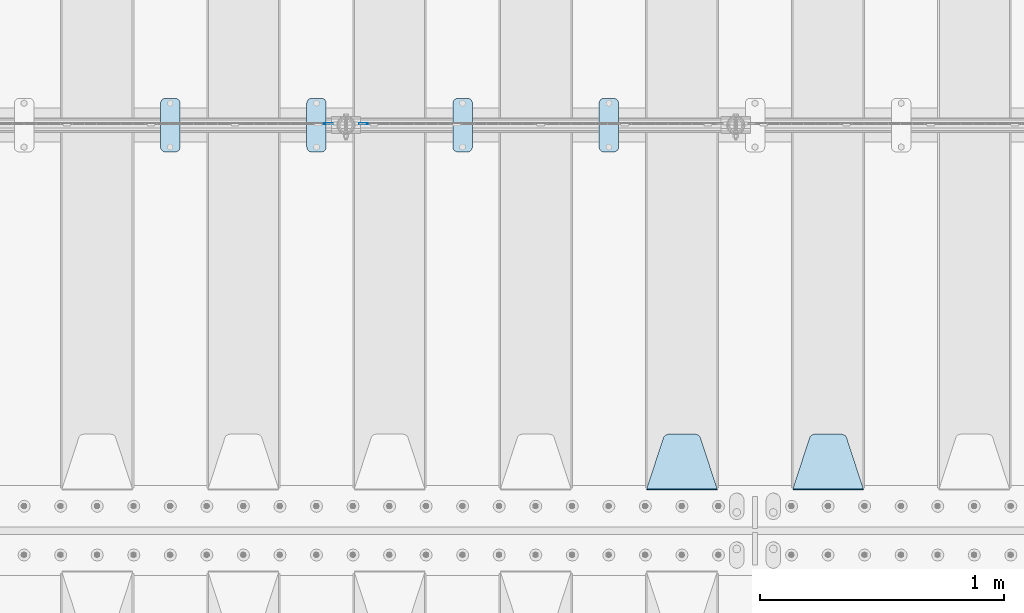
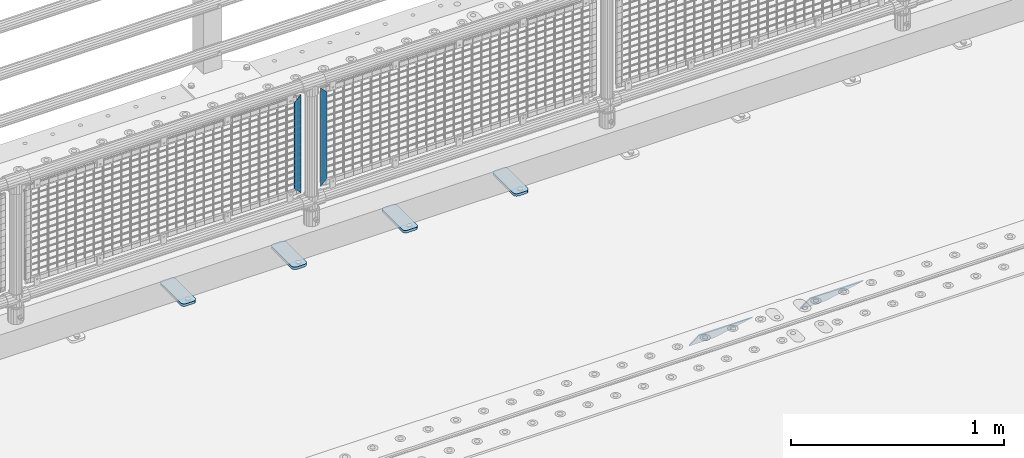
# One storey, part 173 of 208: 8 plates.
"""IFC2X3 building model written with IfcOpenShell, lengths in millimetres."""

import ifcopenshell
import ifcopenshell.guid

model = None  # the IFC model being written
_history = None  # IfcOwnerHistory: only IFC2X3 demands one
_inside = {}  # id of a spatial element -> (the spatial element, [elements in it])
_under = {}  # id of a project, library or spatial element -> (it, [spatial elements below it])
_declared = {}  # id of a project -> (the project, [libraries it declares])
_typed = {}  # id of a type object -> (the type object, [elements of that type])
_made_of = {}  # id of a material, layer set ... -> (it, [elements and type objects made of it])


def new_model(schema):
    """Start an empty IFC model of exactly this schema.

    Asked for "IFC4X3", IfcOpenShell would pick the latest addendum, in which some entities
    have other attributes; the version numbers below select the first issue.
    IFC2X3 requires an IfcOwnerHistory on every rooted entity: one is made here for all.
    """
    global model, _history
    if schema == "IFC4X3":
        model = ifcopenshell.file(schema_version=(4, 3, 0, 0))
    else:
        model = ifcopenshell.file(schema=schema)
    _inside.clear()
    _under.clear()
    _declared.clear()
    _typed.clear()
    _made_of.clear()
    _history = None
    if model.schema == "IFC2X3":
        org = make("IfcOrganization", Name="unknown")
        user = make(
            "IfcPersonAndOrganization",
            ThePerson=make("IfcPerson", FamilyName="unknown"),
            TheOrganization=org,
        )
        app = make(
            "IfcApplication",
            ApplicationDeveloper=org,
            Version="unknown",
            ApplicationFullName="unknown",
            ApplicationIdentifier="unknown",
        )
        _history = make(
            "IfcOwnerHistory",
            OwningUser=user,
            OwningApplication=app,
            ChangeAction="ADDED",
            CreationDate=0,
        )
    return model


def make(cls, **values):
    """One entity of the class cls with the attributes given. An attribute that is None is left unset."""
    return model.create_entity(
        cls, **{name: value for name, value in values.items() if value is not None}
    )


def rooted(cls, **values):
    """An entity with a GlobalId (a new one), such as an element, a storey or a relation."""
    return make(cls, GlobalId=ifcopenshell.guid.new(), OwnerHistory=_history, **values)


def si_unit(unit_type, name, prefix=None):
    """IfcSIUnit, for example si_unit("LENGTHUNIT", "METRE", prefix="MILLI")."""
    return make("IfcSIUnit", UnitType=unit_type, Prefix=prefix, Name=name)


def assignment(units):
    """IfcUnitAssignment: the units of a project."""
    return None if units is None else make("IfcUnitAssignment", Units=units)


def point(xyz):
    """IfcCartesianPoint."""
    return None if xyz is None else make("IfcCartesianPoint", Coordinates=xyz)


def direction(xyz):
    """IfcDirection."""
    return None if xyz is None else make("IfcDirection", DirectionRatios=xyz)


def frame(location, z_axis=None, x_axis=None):
    """IfcAxis2Placement3D, a coordinate frame: its origin and axes. An axis left out is left unset."""
    return make(
        "IfcAxis2Placement3D",
        Location=point(location),
        Axis=direction(z_axis),
        RefDirection=direction(x_axis),
    )


def origin_with_axes():
    """The frame at (0, 0, 0) with the z axis (0, 0, 1) and the x axis (1, 0, 0) written out."""
    return frame((0.0, 0.0, 0.0), z_axis=(0.0, 0.0, 1.0), x_axis=(1.0, 0.0, 0.0))


def place(relative_to, where):
    """IfcLocalPlacement: puts the frame where relative to a parent placement (None: the world)."""
    return make(
        "IfcLocalPlacement", PlacementRelTo=relative_to, RelativePlacement=where
    )


def context(
    kind, dimensions, precision=None, world=None, true_north=None, identifier=None
):
    """IfcGeometricRepresentationContext, for example the 3D "Model" context."""
    return make(
        "IfcGeometricRepresentationContext",
        ContextIdentifier=identifier,
        ContextType=kind,
        CoordinateSpaceDimension=dimensions,
        Precision=precision,
        WorldCoordinateSystem=world,
        TrueNorth=true_north,
    )


def subcontext(parent, identifier, kind, view, scale=None):
    """IfcGeometricRepresentationSubContext, for example "Body" below "Model"."""
    return make(
        "IfcGeometricRepresentationSubContext",
        ContextIdentifier=identifier,
        ContextType=kind,
        ParentContext=parent,
        TargetScale=scale,
        TargetView=view,
    )


def project(units=None, contexts=None):
    """IfcProject with its units and contexts."""
    return rooted(
        "IfcProject",
        Name="project",
        RepresentationContexts=contexts,
        UnitsInContext=assignment(units),
    )


def spatial(cls, under=None, at=None, **own):
    """A site, building, storey or space (cls), placed at a placement, below another one or the project."""
    s = rooted(cls, ObjectPlacement=at, **own)
    if under is not None:
        _under.setdefault(under.id(), (under, []))[1].append(s)
    return s


def faces_of(points, faces, orient=None, outer=None):
    """IfcFace entities. A face is a list of loops; a loop is a list of indices into points, from 0.

    orient and outer hold one flag for each loop. By default every Orientation is true, the
    first loop of a face is its IfcFaceOuterBound and the others are IfcFaceBound.
    """
    made = []
    for i, loops in enumerate(faces):
        bounds = []
        for j, loop in enumerate(loops):
            is_outer = j == 0 if outer is None else outer[i][j]
            bounds.append(
                make(
                    "IfcFaceOuterBound" if is_outer else "IfcFaceBound",
                    Bound=make("IfcPolyLoop", Polygon=[points[k] for k in loop]),
                    Orientation=True if orient is None else orient[i][j],
                )
            )
        made.append(make("IfcFace", Bounds=bounds))
    return made


def faceted_brep(points, faces, orient=None, outer=None, voids=None):
    """IfcFacetedBrep: a solid bounded by flat faces; with voids (closed shells), ...WithVoids."""
    shared = [point(p) for p in points]
    hull = make("IfcClosedShell", CfsFaces=faces_of(shared, faces, orient, outer))
    if voids is None:
        return make("IfcFacetedBrep", Outer=hull)
    return make(
        "IfcFacetedBrepWithVoids",
        Outer=hull,
        Voids=[
            make(cls, CfsFaces=faces_of(shared, fs, o, b)) for cls, fs, o, b in voids
        ],
    )


def shape(context_of_items, identifier, shape_type, items):
    """IfcShapeRepresentation: the items that make up one representation, for example the "Body"."""
    return make(
        "IfcShapeRepresentation",
        ContextOfItems=context_of_items,
        RepresentationIdentifier=identifier,
        RepresentationType=shape_type,
        Items=items,
    )


def material(Name=None, Category=None):
    """IfcMaterial."""
    return make("IfcMaterial", Name=Name, Category=Category)


def made_of(thing, what):
    """Note that an element or type object is made of a material, layer set ...; save() writes the relation."""
    if what is not None:
        _made_of.setdefault(what.id(), (what, []))[1].append(thing)
    return thing


def type_object(cls, material=None, **own):
    """A type object (cls), such as IfcWallType, which elements share."""
    return made_of(rooted(cls, **own), material)


def element(
    cls,
    number,
    at=None,
    inside=None,
    cuts=None,
    type_object=None,
    material=None,
    context=None,
    identifier="Body",
    shape_type=None,
    held_by="IfcProductDefinitionShape",
    body=None,
    shapes=None,
    **own,
):
    """One element of the class cls, such as IfcWall. Its Tag is "e" and its number.

    at: its placement. inside: the storey or other place that contains it. cuts: it is an
    opening in that element (IfcRelVoidsElement). A single representation is given by context,
    identifier, shape_type and body (its items); several are given by shapes. held_by: the class
    of the entity that holds the representations. save() writes the other relations.
    """
    e = rooted(cls, Tag="e%d" % number, ObjectPlacement=at, **own)
    if body is not None:
        shapes = [shape(context, identifier, shape_type, body)]
    if shapes is not None:
        e.Representation = make(held_by, Representations=shapes)
    if inside is not None:
        _inside.setdefault(inside.id(), (inside, []))[1].append(e)
    if cuts is not None:
        rooted(
            "IfcRelVoidsElement", RelatingBuildingElement=cuts, RelatedOpeningElement=e
        )
    if type_object is not None:
        _typed.setdefault(type_object.id(), (type_object, []))[1].append(e)
    return made_of(e, material)


def aggregate(whole, parts):
    """IfcRelAggregates: a whole, such as a stair, and the parts it consists of."""
    return rooted("IfcRelAggregates", RelatingObject=whole, RelatedObjects=parts)


def save(model, path):
    """Write the relations noted so far, then the file.

    IfcRelAggregates (storeys below a building ...), IfcRelContainedInSpatialStructure (elements
    in a storey), IfcRelDefinesByType, IfcRelAssociatesMaterial and IfcRelDeclares: one each for
    every whole, place, type object, material and project.
    """
    for whole, parts in _under.values():
        aggregate(whole, parts)
    for where, things in _inside.values():
        rooted(
            "IfcRelContainedInSpatialStructure",
            RelatedElements=things,
            RelatingStructure=where,
        )
    for kind, things in _typed.values():
        rooted("IfcRelDefinesByType", RelatedObjects=things, RelatingType=kind)
    for what, things in _made_of.values():
        rooted("IfcRelAssociatesMaterial", RelatedObjects=things, RelatingMaterial=what)
    for by, libraries in _declared.values():
        rooted("IfcRelDeclares", RelatingContext=by, RelatedDefinitions=libraries)
    model.write(path)


model = new_model("IFC2X3")

# Units and contexts
model_context = context("Model", 3, precision=1e-05, world=origin_with_axes())
body_context = subcontext(model_context, "Body", "Model", "MODEL_VIEW")
ifc_project = project(units=[si_unit("LENGTHUNIT", "METRE", prefix="MILLI"), si_unit("AREAUNIT", "SQUARE_METRE"), si_unit("VOLUMEUNIT", "CUBIC_METRE"), si_unit("MASSUNIT", "GRAM", prefix="KILO"), si_unit("TIMEUNIT", "SECOND"), si_unit("PLANEANGLEUNIT", "RADIAN"), si_unit("SOLIDANGLEUNIT", "STERADIAN"), si_unit("THERMODYNAMICTEMPERATUREUNIT", "DEGREE_CELSIUS"), si_unit("LUMINOUSINTENSITYUNIT", "LUMEN")], contexts=[model_context])

# Site, building, storey
site_placement = place(None, origin_with_axes())
site = spatial("IfcSite", under=ifc_project, at=site_placement, CompositionType="ELEMENT")
building_placement = place(site_placement, origin_with_axes())
building = spatial("IfcBuilding", under=site, at=building_placement, Name="Standard", CompositionType="ELEMENT")
storey_placement = place(building_placement, origin_with_axes())
storey = spatial("IfcBuildingStorey", under=building, at=storey_placement, Name="Undefined", CompositionType="ELEMENT", Elevation=0.0)

# Plates
ifc_material_1 = material(Name="STEEL/S355J2")
plate_type_1 = type_object("IfcPlateType", PredefinedType="NOTDEFINED")
plate_1_placement = place(storey_placement, frame((-37590.0, 4774.5, 21.0199999999977), z_axis=(1.0, 0.0, 0.0), x_axis=(0.0, -1.0, 0.0)))
element("IfcPlate", 1, at=plate_1_placement, inside=storey, type_object=plate_type_1, material=ifc_material_1, context=body_context, shape_type="Brep", body=[
    faceted_brep([(0.0, -7.0, 20.0), (0.0, -7.0, 60.0), (0.0, 7.0, 60.0), (0.0, 7.0, 20.0), (0.384294391935327, -7.0, 63.9018064403208), (0.384294391935327, 7.0, 63.9018064403208), (1.52240934977453, -7.0, 67.6536686473009), (1.52240934977453, 7.0, 67.6536686473009), (3.37060775394912, -7.0, 71.1114046603907), (3.37060775394912, 7.0, 71.1114046603907), (5.85786437626939, -7.0, 74.1421356237297), (5.85786437626939, 7.0, 74.1421356237297), (8.8885953396084, -7.0, 76.62939224605), (8.8885953396084, 7.0, 76.62939224605), (12.3463313526981, -7.0, 78.4775906502255), (12.3463313526981, 7.0, 78.4775906502255), (16.0981935596774, -7.0, 79.6157056080629), (16.0981935596774, 7.0, 79.6157056080629), (20.0, -7.0, 80.0), (20.0, 7.0, 80.0), (200.0, -7.0, 80.0), (200.0, 7.0, 80.0), (203.901806440323, -7.0, 79.6157056080629), (203.901806440323, 7.0, 79.6157056080629), (207.653668647302, -7.0, 78.4775906502255), (207.653668647302, 7.0, 78.4775906502255), (211.111404660393, -7.0, 76.62939224605), (211.111404660393, 7.0, 76.62939224605), (214.142135623731, -7.0, 74.1421356237297), (214.142135623731, 7.0, 74.1421356237297), (216.629392246051, -7.0, 71.1114046603907), (216.629392246051, 7.0, 71.1114046603907), (218.477590650225, -7.0, 67.6536686473009), (218.477590650225, 7.0, 67.6536686473009), (219.615705608065, -7.0, 63.9018064403208), (219.615705608065, 7.0, 63.9018064403208), (220.0, -7.0, 60.0), (220.0, 7.0, 60.0), (220.0, -7.0, 20.0), (220.0, 7.0, 20.0), (219.615705608065, -7.0, 16.0981935596792), (219.615705608065, 7.0, 16.0981935596792), (218.477590650225, -7.0, 12.3463313526991), (218.477590650225, 7.0, 12.3463313526991), (216.629392246051, -7.0, 8.88859533960931), (216.629392246051, 7.0, 8.88859533960931), (214.142135623731, -7.0, 5.8578643762703), (214.142135623731, 7.0, 5.8578643762703), (211.111404660393, -7.0, 3.37060775395003), (211.111404660393, 7.0, 3.37060775395003), (207.653668647302, -7.0, 1.52240934977453), (207.653668647302, 7.0, 1.52240934977453), (203.901806440323, -7.0, 0.384294391937146), (203.901806440323, 7.0, 0.384294391937146), (200.0, -7.0, 0.0), (200.0, 7.0, 0.0), (20.0, -7.0, 0.0), (20.0, 7.0, 0.0), (16.0981935596774, -7.0, 0.384294391937146), (16.0981935596774, 7.0, 0.384294391937146), (12.3463313526981, -7.0, 1.52240934977453), (12.3463313526981, 7.0, 1.52240934977453), (8.8885953396084, -7.0, 3.37060775395003), (8.8885953396084, 7.0, 3.37060775395003), (5.85786437626939, -7.0, 5.8578643762703), (5.85786437626939, 7.0, 5.8578643762703), (3.37060775394912, -7.0, 8.88859533960931), (3.37060775394912, 7.0, 8.88859533960931), (1.52240934977453, -7.0, 12.3463313526991), (1.52240934977453, 7.0, 12.3463313526991), (0.384294391935327, -7.0, 16.0981935596792), (0.384294391935327, 7.0, 16.0981935596792)], [[[0, 1, 2, 3]], [[1, 4, 5, 2]], [[4, 6, 7, 5]], [[6, 8, 9, 7]], [[8, 10, 11, 9]], [[10, 12, 13, 11]], [[12, 14, 15, 13]], [[14, 16, 17, 15]], [[16, 18, 19, 17]], [[18, 20, 21, 19]], [[20, 22, 23, 21]], [[22, 24, 25, 23]], [[24, 26, 27, 25]], [[26, 28, 29, 27]], [[28, 30, 31, 29]], [[30, 32, 33, 31]], [[32, 34, 35, 33]], [[34, 36, 37, 35]], [[36, 38, 39, 37]], [[38, 40, 41, 39]], [[40, 42, 43, 41]], [[42, 44, 45, 43]], [[44, 46, 47, 45]], [[46, 48, 49, 47]], [[48, 50, 51, 49]], [[50, 52, 53, 51]], [[52, 54, 55, 53]], [[54, 56, 57, 55]], [[56, 58, 59, 57]], [[58, 60, 61, 59]], [[60, 62, 63, 61]], [[62, 64, 65, 63]], [[64, 66, 67, 65]], [[66, 68, 69, 67]], [[68, 70, 71, 69]], [[70, 0, 3, 71]], [[5, 7, 9, 11, 13, 15, 17, 19, 21, 23, 25, 27, 29, 31, 33, 35, 37, 39, 41, 43, 45, 47, 49, 51, 53, 55, 57, 59, 61, 63, 65, 67, 69, 71, 3, 2]], [[70, 68, 66, 64, 62, 60, 58, 56, 54, 52, 50, 48, 46, 44, 42, 40, 38, 36, 34, 32, 30, 28, 26, 24, 22, 20, 18, 16, 14, 12, 10, 8, 6, 4, 1, 0]]]),
])
plate_2_placement = place(storey_placement, frame((-38190.0, 4774.5, 21.0199999999977), z_axis=(1.0, 0.0, 0.0), x_axis=(0.0, -1.0, 0.0)))
element("IfcPlate", 2, at=plate_2_placement, inside=storey, type_object=plate_type_1, material=ifc_material_1, context=body_context, shape_type="Brep", body=[
    faceted_brep([(0.0, -7.0, 20.0), (0.0, -7.0, 60.0), (0.0, 7.0, 60.0), (0.0, 7.0, 20.0), (0.384294391935327, -7.0, 63.9018064403208), (0.384294391935327, 7.0, 63.9018064403208), (1.52240934977453, -7.0, 67.6536686473009), (1.52240934977453, 7.0, 67.6536686473009), (3.37060775394912, -7.0, 71.1114046603907), (3.37060775394912, 7.0, 71.1114046603907), (5.85786437626939, -7.0, 74.1421356237297), (5.85786437626939, 7.0, 74.1421356237297), (8.8885953396084, -7.0, 76.62939224605), (8.8885953396084, 7.0, 76.62939224605), (12.3463313526981, -7.0, 78.4775906502255), (12.3463313526981, 7.0, 78.4775906502255), (16.0981935596774, -7.0, 79.6157056080629), (16.0981935596774, 7.0, 79.6157056080629), (20.0, -7.0, 80.0), (20.0, 7.0, 80.0), (200.0, -7.0, 80.0), (200.0, 7.0, 80.0), (203.901806440323, -7.0, 79.6157056080629), (203.901806440323, 7.0, 79.6157056080629), (207.653668647302, -7.0, 78.4775906502255), (207.653668647302, 7.0, 78.4775906502255), (211.111404660393, -7.0, 76.62939224605), (211.111404660393, 7.0, 76.62939224605), (214.142135623731, -7.0, 74.1421356237297), (214.142135623731, 7.0, 74.1421356237297), (216.629392246051, -7.0, 71.1114046603907), (216.629392246051, 7.0, 71.1114046603907), (218.477590650225, -7.0, 67.6536686473009), (218.477590650225, 7.0, 67.6536686473009), (219.615705608065, -7.0, 63.9018064403208), (219.615705608065, 7.0, 63.9018064403208), (220.0, -7.0, 60.0), (220.0, 7.0, 60.0), (220.0, -7.0, 20.0), (220.0, 7.0, 20.0), (219.615705608065, -7.0, 16.0981935596792), (219.615705608065, 7.0, 16.0981935596792), (218.477590650225, -7.0, 12.3463313526991), (218.477590650225, 7.0, 12.3463313526991), (216.629392246051, -7.0, 8.88859533960931), (216.629392246051, 7.0, 8.88859533960931), (214.142135623731, -7.0, 5.8578643762703), (214.142135623731, 7.0, 5.8578643762703), (211.111404660393, -7.0, 3.37060775395003), (211.111404660393, 7.0, 3.37060775395003), (207.653668647302, -7.0, 1.52240934977453), (207.653668647302, 7.0, 1.52240934977453), (203.901806440323, -7.0, 0.384294391937146), (203.901806440323, 7.0, 0.384294391937146), (200.0, -7.0, 0.0), (200.0, 7.0, 0.0), (20.0, -7.0, 0.0), (20.0, 7.0, 0.0), (16.0981935596774, -7.0, 0.384294391937146), (16.0981935596774, 7.0, 0.384294391937146), (12.3463313526981, -7.0, 1.52240934977453), (12.3463313526981, 7.0, 1.52240934977453), (8.8885953396084, -7.0, 3.37060775395003), (8.8885953396084, 7.0, 3.37060775395003), (5.85786437626939, -7.0, 5.8578643762703), (5.85786437626939, 7.0, 5.8578643762703), (3.37060775394912, -7.0, 8.88859533960931), (3.37060775394912, 7.0, 8.88859533960931), (1.52240934977453, -7.0, 12.3463313526991), (1.52240934977453, 7.0, 12.3463313526991), (0.384294391935327, -7.0, 16.0981935596792), (0.384294391935327, 7.0, 16.0981935596792)], [[[0, 1, 2, 3]], [[1, 4, 5, 2]], [[4, 6, 7, 5]], [[6, 8, 9, 7]], [[8, 10, 11, 9]], [[10, 12, 13, 11]], [[12, 14, 15, 13]], [[14, 16, 17, 15]], [[16, 18, 19, 17]], [[18, 20, 21, 19]], [[20, 22, 23, 21]], [[22, 24, 25, 23]], [[24, 26, 27, 25]], [[26, 28, 29, 27]], [[28, 30, 31, 29]], [[30, 32, 33, 31]], [[32, 34, 35, 33]], [[34, 36, 37, 35]], [[36, 38, 39, 37]], [[38, 40, 41, 39]], [[40, 42, 43, 41]], [[42, 44, 45, 43]], [[44, 46, 47, 45]], [[46, 48, 49, 47]], [[48, 50, 51, 49]], [[50, 52, 53, 51]], [[52, 54, 55, 53]], [[54, 56, 57, 55]], [[56, 58, 59, 57]], [[58, 60, 61, 59]], [[60, 62, 63, 61]], [[62, 64, 65, 63]], [[64, 66, 67, 65]], [[66, 68, 69, 67]], [[68, 70, 71, 69]], [[70, 0, 3, 71]], [[5, 7, 9, 11, 13, 15, 17, 19, 21, 23, 25, 27, 29, 31, 33, 35, 37, 39, 41, 43, 45, 47, 49, 51, 53, 55, 57, 59, 61, 63, 65, 67, 69, 71, 3, 2]], [[70, 68, 66, 64, 62, 60, 58, 56, 54, 52, 50, 48, 46, 44, 42, 40, 38, 36, 34, 32, 30, 28, 26, 24, 22, 20, 18, 16, 14, 12, 10, 8, 6, 4, 1, 0]]]),
])
plate_3_placement = place(storey_placement, frame((-38790.0, 4774.5, 21.0199999999977), z_axis=(1.0, 0.0, 0.0), x_axis=(0.0, -1.0, 0.0)))
element("IfcPlate", 3, at=plate_3_placement, inside=storey, type_object=plate_type_1, material=ifc_material_1, context=body_context, shape_type="Brep", body=[
    faceted_brep([(0.0, -7.0, 20.0), (0.0, -7.0, 60.0), (0.0, 7.0, 60.0), (0.0, 7.0, 20.0), (0.384294391935327, -7.0, 63.9018064403208), (0.384294391935327, 7.0, 63.9018064403208), (1.52240934977453, -7.0, 67.6536686473009), (1.52240934977453, 7.0, 67.6536686473009), (3.37060775394912, -7.0, 71.1114046603907), (3.37060775394912, 7.0, 71.1114046603907), (5.85786437626939, -7.0, 74.1421356237297), (5.85786437626939, 7.0, 74.1421356237297), (8.8885953396084, -7.0, 76.62939224605), (8.8885953396084, 7.0, 76.62939224605), (12.3463313526981, -7.0, 78.4775906502255), (12.3463313526981, 7.0, 78.4775906502255), (16.0981935596774, -7.0, 79.6157056080629), (16.0981935596774, 7.0, 79.6157056080629), (20.0, -7.0, 80.0), (20.0, 7.0, 80.0), (200.0, -7.0, 80.0), (200.0, 7.0, 80.0), (203.901806440323, -7.0, 79.6157056080629), (203.901806440323, 7.0, 79.6157056080629), (207.653668647302, -7.0, 78.4775906502255), (207.653668647302, 7.0, 78.4775906502255), (211.111404660393, -7.0, 76.62939224605), (211.111404660393, 7.0, 76.62939224605), (214.142135623731, -7.0, 74.1421356237297), (214.142135623731, 7.0, 74.1421356237297), (216.629392246051, -7.0, 71.1114046603907), (216.629392246051, 7.0, 71.1114046603907), (218.477590650225, -7.0, 67.6536686473009), (218.477590650225, 7.0, 67.6536686473009), (219.615705608065, -7.0, 63.9018064403208), (219.615705608065, 7.0, 63.9018064403208), (220.0, -7.0, 60.0), (220.0, 7.0, 60.0), (220.0, -7.0, 20.0), (220.0, 7.0, 20.0), (219.615705608065, -7.0, 16.0981935596792), (219.615705608065, 7.0, 16.0981935596792), (218.477590650225, -7.0, 12.3463313526991), (218.477590650225, 7.0, 12.3463313526991), (216.629392246051, -7.0, 8.88859533960931), (216.629392246051, 7.0, 8.88859533960931), (214.142135623731, -7.0, 5.8578643762703), (214.142135623731, 7.0, 5.8578643762703), (211.111404660393, -7.0, 3.37060775395003), (211.111404660393, 7.0, 3.37060775395003), (207.653668647302, -7.0, 1.52240934977453), (207.653668647302, 7.0, 1.52240934977453), (203.901806440323, -7.0, 0.384294391937146), (203.901806440323, 7.0, 0.384294391937146), (200.0, -7.0, 0.0), (200.0, 7.0, 0.0), (20.0, -7.0, 0.0), (20.0, 7.0, 0.0), (16.0981935596774, -7.0, 0.384294391937146), (16.0981935596774, 7.0, 0.384294391937146), (12.3463313526981, -7.0, 1.52240934977453), (12.3463313526981, 7.0, 1.52240934977453), (8.8885953396084, -7.0, 3.37060775395003), (8.8885953396084, 7.0, 3.37060775395003), (5.85786437626939, -7.0, 5.8578643762703), (5.85786437626939, 7.0, 5.8578643762703), (3.37060775394912, -7.0, 8.88859533960931), (3.37060775394912, 7.0, 8.88859533960931), (1.52240934977453, -7.0, 12.3463313526991), (1.52240934977453, 7.0, 12.3463313526991), (0.384294391935327, -7.0, 16.0981935596792), (0.384294391935327, 7.0, 16.0981935596792)], [[[0, 1, 2, 3]], [[1, 4, 5, 2]], [[4, 6, 7, 5]], [[6, 8, 9, 7]], [[8, 10, 11, 9]], [[10, 12, 13, 11]], [[12, 14, 15, 13]], [[14, 16, 17, 15]], [[16, 18, 19, 17]], [[18, 20, 21, 19]], [[20, 22, 23, 21]], [[22, 24, 25, 23]], [[24, 26, 27, 25]], [[26, 28, 29, 27]], [[28, 30, 31, 29]], [[30, 32, 33, 31]], [[32, 34, 35, 33]], [[34, 36, 37, 35]], [[36, 38, 39, 37]], [[38, 40, 41, 39]], [[40, 42, 43, 41]], [[42, 44, 45, 43]], [[44, 46, 47, 45]], [[46, 48, 49, 47]], [[48, 50, 51, 49]], [[50, 52, 53, 51]], [[52, 54, 55, 53]], [[54, 56, 57, 55]], [[56, 58, 59, 57]], [[58, 60, 61, 59]], [[60, 62, 63, 61]], [[62, 64, 65, 63]], [[64, 66, 67, 65]], [[66, 68, 69, 67]], [[68, 70, 71, 69]], [[70, 0, 3, 71]], [[5, 7, 9, 11, 13, 15, 17, 19, 21, 23, 25, 27, 29, 31, 33, 35, 37, 39, 41, 43, 45, 47, 49, 51, 53, 55, 57, 59, 61, 63, 65, 67, 69, 71, 3, 2]], [[70, 68, 66, 64, 62, 60, 58, 56, 54, 52, 50, 48, 46, 44, 42, 40, 38, 36, 34, 32, 30, 28, 26, 24, 22, 20, 18, 16, 14, 12, 10, 8, 6, 4, 1, 0]]]),
])
plate_4_placement = place(storey_placement, frame((-39390.0, 4774.5, 21.0199999999977), z_axis=(1.0, 0.0, 0.0), x_axis=(0.0, -1.0, 0.0)))
element("IfcPlate", 4, at=plate_4_placement, inside=storey, type_object=plate_type_1, material=ifc_material_1, context=body_context, shape_type="Brep", body=[
    faceted_brep([(0.0, -7.0, 20.0), (0.0, -7.0, 60.0), (0.0, 7.0, 60.0), (0.0, 7.0, 20.0), (0.384294391935327, -7.0, 63.9018064403208), (0.384294391935327, 7.0, 63.9018064403208), (1.52240934977453, -7.0, 67.6536686473009), (1.52240934977453, 7.0, 67.6536686473009), (3.37060775394912, -7.0, 71.1114046603907), (3.37060775394912, 7.0, 71.1114046603907), (5.85786437626939, -7.0, 74.1421356237297), (5.85786437626939, 7.0, 74.1421356237297), (8.8885953396084, -7.0, 76.62939224605), (8.8885953396084, 7.0, 76.62939224605), (12.3463313526981, -7.0, 78.4775906502255), (12.3463313526981, 7.0, 78.4775906502255), (16.0981935596774, -7.0, 79.6157056080629), (16.0981935596774, 7.0, 79.6157056080629), (20.0, -7.0, 80.0), (20.0, 7.0, 80.0), (200.0, -7.0, 80.0), (200.0, 7.0, 80.0), (203.901806440323, -7.0, 79.6157056080629), (203.901806440323, 7.0, 79.6157056080629), (207.653668647302, -7.0, 78.4775906502255), (207.653668647302, 7.0, 78.4775906502255), (211.111404660393, -7.0, 76.62939224605), (211.111404660393, 7.0, 76.62939224605), (214.142135623731, -7.0, 74.1421356237297), (214.142135623731, 7.0, 74.1421356237297), (216.629392246051, -7.0, 71.1114046603907), (216.629392246051, 7.0, 71.1114046603907), (218.477590650225, -7.0, 67.6536686473009), (218.477590650225, 7.0, 67.6536686473009), (219.615705608065, -7.0, 63.9018064403208), (219.615705608065, 7.0, 63.9018064403208), (220.0, -7.0, 60.0), (220.0, 7.0, 60.0), (220.0, -7.0, 20.0), (220.0, 7.0, 20.0), (219.615705608065, -7.0, 16.0981935596792), (219.615705608065, 7.0, 16.0981935596792), (218.477590650225, -7.0, 12.3463313526991), (218.477590650225, 7.0, 12.3463313526991), (216.629392246051, -7.0, 8.88859533960931), (216.629392246051, 7.0, 8.88859533960931), (214.142135623731, -7.0, 5.8578643762703), (214.142135623731, 7.0, 5.8578643762703), (211.111404660393, -7.0, 3.37060775395003), (211.111404660393, 7.0, 3.37060775395003), (207.653668647302, -7.0, 1.52240934977453), (207.653668647302, 7.0, 1.52240934977453), (203.901806440323, -7.0, 0.384294391937146), (203.901806440323, 7.0, 0.384294391937146), (200.0, -7.0, 0.0), (200.0, 7.0, 0.0), (20.0, -7.0, 0.0), (20.0, 7.0, 0.0), (16.0981935596774, -7.0, 0.384294391937146), (16.0981935596774, 7.0, 0.384294391937146), (12.3463313526981, -7.0, 1.52240934977453), (12.3463313526981, 7.0, 1.52240934977453), (8.8885953396084, -7.0, 3.37060775395003), (8.8885953396084, 7.0, 3.37060775395003), (5.85786437626939, -7.0, 5.8578643762703), (5.85786437626939, 7.0, 5.8578643762703), (3.37060775394912, -7.0, 8.88859533960931), (3.37060775394912, 7.0, 8.88859533960931), (1.52240934977453, -7.0, 12.3463313526991), (1.52240934977453, 7.0, 12.3463313526991), (0.384294391935327, -7.0, 16.0981935596792), (0.384294391935327, 7.0, 16.0981935596792)], [[[0, 1, 2, 3]], [[1, 4, 5, 2]], [[4, 6, 7, 5]], [[6, 8, 9, 7]], [[8, 10, 11, 9]], [[10, 12, 13, 11]], [[12, 14, 15, 13]], [[14, 16, 17, 15]], [[16, 18, 19, 17]], [[18, 20, 21, 19]], [[20, 22, 23, 21]], [[22, 24, 25, 23]], [[24, 26, 27, 25]], [[26, 28, 29, 27]], [[28, 30, 31, 29]], [[30, 32, 33, 31]], [[32, 34, 35, 33]], [[34, 36, 37, 35]], [[36, 38, 39, 37]], [[38, 40, 41, 39]], [[40, 42, 43, 41]], [[42, 44, 45, 43]], [[44, 46, 47, 45]], [[46, 48, 49, 47]], [[48, 50, 51, 49]], [[50, 52, 53, 51]], [[52, 54, 55, 53]], [[54, 56, 57, 55]], [[56, 58, 59, 57]], [[58, 60, 61, 59]], [[60, 62, 63, 61]], [[62, 64, 65, 63]], [[64, 66, 67, 65]], [[66, 68, 69, 67]], [[68, 70, 71, 69]], [[70, 0, 3, 71]], [[5, 7, 9, 11, 13, 15, 17, 19, 21, 23, 25, 27, 29, 31, 33, 35, 37, 39, 41, 43, 45, 47, 49, 51, 53, 55, 57, 59, 61, 63, 65, 67, 69, 71, 3, 2]], [[70, 68, 66, 64, 62, 60, 58, 56, 54, 52, 50, 48, 46, 44, 42, 40, 38, 36, 34, 32, 30, 28, 26, 24, 22, 20, 18, 16, 14, 12, 10, 8, 6, 4, 1, 0]]]),
])
ifc_material_2 = material(Name="STEEL/S355N")
plate_type_2 = type_object("IfcPlateType", PredefinedType="NOTDEFINED")
plate_5_placement = place(storey_placement, frame((-36505.0, 3168.23223304702, -1.76776695296758), z_axis=(0.0, 0.707106781186547, -0.707106781186548), x_axis=(-1.0, 0.0, 0.0)))
element("IfcPlate", 5, at=plate_5_placement, inside=storey, type_object=plate_type_2, material=ifc_material_2, context=body_context, shape_type="Brep", body=[
    faceted_brep([(0.0, -2.5, 0.0), (69.345504679477, -2.5, 300.17173142483), (69.345504679477, 2.5, 300.17173142483), (0.0, 2.5, 0.0), (70.9274061199576, -2.5, 304.897442415399), (70.9274061199576, 2.5, 304.8974424154), (73.3818627772307, -2.5, 309.234538108527), (73.3818627772307, 2.5, 309.234538108527), (76.6187032999551, -2.5, 313.023683126103), (76.6187032999551, 2.5, 313.023683126103), (80.5190132704993, -2.5, 316.125672595371), (80.5190132704993, 2.5, 316.125672595371), (84.9395038596849, -2.5, 318.426546230476), (84.9395038596849, 2.50000000000091, 318.426546230476), (89.7177759439219, -2.5, 319.841774983275), (89.7177759439219, 2.50000000000091, 319.841774983275), (94.678286292652, -2.49999999999909, 320.319366455078), (94.678286292652, 2.5, 320.319366455078), (195.321713707348, -2.49999999999909, 320.319366455078), (195.321713707348, 2.5, 320.319366455078), (200.282224056078, -2.5, 319.841774983275), (200.282224056078, 2.5, 319.841774983274), (205.060496140315, -2.5, 318.426546230475), (205.060496140315, 2.5, 318.426546230475), (209.480986729501, -2.5, 316.125672595371), (209.480986729501, 2.50000000000091, 316.125672595371), (213.381296700045, -2.5, 313.023683126102), (213.381296700045, 2.5, 313.023683126102), (216.618137222769, -2.5, 309.234538108526), (216.618137222769, 2.5, 309.234538108527), (219.072593880042, -2.5, 304.897442415399), (219.072593880042, 2.5, 304.897442415399), (220.654495320523, -2.5, 300.17173142483), (220.654495320523, 2.5, 300.17173142483), (290.0, -2.5, 0.0), (290.0, 2.5, 0.0)], [[[0, 1, 2, 3]], [[1, 4, 5, 2]], [[4, 6, 7, 5]], [[6, 8, 9, 7]], [[8, 10, 11, 9]], [[10, 12, 13, 11]], [[12, 14, 15, 13]], [[14, 16, 17, 15]], [[16, 18, 19, 17]], [[18, 20, 21, 19]], [[20, 22, 23, 21]], [[22, 24, 25, 23]], [[24, 26, 27, 25]], [[26, 28, 29, 27]], [[28, 30, 31, 29]], [[30, 32, 33, 31]], [[32, 34, 35, 33]], [[34, 0, 3, 35]], [[5, 7, 9, 11, 13, 15, 17, 19, 21, 23, 25, 27, 29, 31, 33, 35, 3, 2]], [[34, 32, 30, 28, 26, 24, 22, 20, 18, 16, 14, 12, 10, 8, 6, 4, 1, 0]]]),
])
plate_6_placement = place(storey_placement, frame((-37105.0, 3168.23223304702, -1.76776695296758), z_axis=(0.0, 0.707106781186547, -0.707106781186548), x_axis=(-1.0, 0.0, 0.0)))
element("IfcPlate", 6, at=plate_6_placement, inside=storey, type_object=plate_type_2, material=ifc_material_2, context=body_context, shape_type="Brep", body=[
    faceted_brep([(0.0, -2.5, 0.0), (69.345504679477, -2.5, 300.17173142483), (69.345504679477, 2.5, 300.17173142483), (0.0, 2.5, 0.0), (70.9274061199576, -2.5, 304.897442415399), (70.9274061199576, 2.5, 304.8974424154), (73.3818627772307, -2.5, 309.234538108527), (73.3818627772307, 2.5, 309.234538108527), (76.6187032999551, -2.5, 313.023683126103), (76.6187032999551, 2.5, 313.023683126103), (80.5190132704993, -2.5, 316.125672595371), (80.5190132704993, 2.5, 316.125672595371), (84.9395038596849, -2.5, 318.426546230476), (84.9395038596849, 2.50000000000091, 318.426546230476), (89.7177759439219, -2.5, 319.841774983275), (89.7177759439219, 2.50000000000091, 319.841774983275), (94.678286292652, -2.49999999999909, 320.319366455078), (94.678286292652, 2.5, 320.319366455078), (195.321713707348, -2.49999999999909, 320.319366455078), (195.321713707348, 2.5, 320.319366455078), (200.282224056078, -2.5, 319.841774983275), (200.282224056078, 2.5, 319.841774983274), (205.060496140315, -2.5, 318.426546230475), (205.060496140315, 2.5, 318.426546230475), (209.480986729501, -2.5, 316.125672595371), (209.480986729501, 2.50000000000091, 316.125672595371), (213.381296700045, -2.5, 313.023683126102), (213.381296700045, 2.5, 313.023683126102), (216.618137222769, -2.5, 309.234538108526), (216.618137222769, 2.5, 309.234538108527), (219.072593880042, -2.5, 304.897442415399), (219.072593880042, 2.5, 304.897442415399), (220.654495320523, -2.5, 300.17173142483), (220.654495320523, 2.5, 300.17173142483), (290.0, -2.5, 0.0), (290.0, 2.5, 0.0)], [[[0, 1, 2, 3]], [[1, 4, 5, 2]], [[4, 6, 7, 5]], [[6, 8, 9, 7]], [[8, 10, 11, 9]], [[10, 12, 13, 11]], [[12, 14, 15, 13]], [[14, 16, 17, 15]], [[16, 18, 19, 17]], [[18, 20, 21, 19]], [[20, 22, 23, 21]], [[22, 24, 25, 23]], [[24, 26, 27, 25]], [[26, 28, 29, 27]], [[28, 30, 31, 29]], [[30, 32, 33, 31]], [[32, 34, 35, 33]], [[34, 0, 3, 35]], [[5, 7, 9, 11, 13, 15, 17, 19, 21, 23, 25, 27, 29, 31, 33, 35, 3, 2]], [[34, 32, 30, 28, 26, 24, 22, 20, 18, 16, 14, 12, 10, 8, 6, 4, 1, 0]]]),
])
ifc_material_3 = material(Name="Misc_Undefined")
plate_type_3 = type_object("IfcPlateType", PredefinedType="NOTDEFINED")
plate_7_placement = place(storey_placement, frame((-38540.490286459, 4670.5, 879.519963133601), z_axis=(-0.707008801899319, 0.0, -0.707204746899291), x_axis=(-0.70720474689929, 0.0, 0.707008801899319)))
element("IfcPlate", 7, at=plate_7_placement, inside=storey, type_object=plate_type_3, material=ifc_material_3, context=body_context, shape_type="Brep", body=[
    faceted_brep([(0.0, -1.49999999999909, 3.63797880709171e-12), (-348.55218505859, -1.5, 348.655029296875), (-348.55218505859, 1.5, 348.655029296875), (0.0, 1.50000000000182, 3.63797880709171e-12), (-348.544891357418, -1.5, 398.152496337894), (-348.544891357418, 1.5, 398.152496337894), (49.5043945312536, -1.5, 7.6397554948926e-11), (49.5043945312536, 1.5, 7.6397554948926e-11)], [[[0, 1, 2, 3]], [[1, 4, 5, 2]], [[4, 6, 7, 5]], [[6, 0, 3, 7]], [[5, 7, 3, 2]], [[6, 4, 1, 0]]]),
])
plate_8_placement = place(storey_placement, frame((-38717.5003125164, 4670.5, 879.52), z_axis=(0.707103624179499, 0.0, -0.707109938179501), x_axis=(0.707109938179495, 0.0, 0.707103624179505)))
element("IfcPlate", 8, at=plate_8_placement, inside=storey, type_object=plate_type_3, material=ifc_material_3, context=body_context, shape_type="Brep", body=[
    faceted_brep([(0.0, -1.49999999999909, 3.63797880709171e-12), (-348.605163574219, -1.5, 348.602081298821), (-348.605163574219, 1.5, 348.602081298821), (0.0, 1.50000000000182, 3.63797880709171e-12), (-348.605163574219, -1.5, 398.099334716793), (-348.605163574219, 1.5, 398.099334716793), (49.4976959228516, -1.5, 6.91215973347425e-11), (49.4976959228516, 1.5, 6.91215973347425e-11)], [[[0, 1, 2, 3]], [[1, 4, 5, 2]], [[4, 6, 7, 5]], [[6, 0, 3, 7]], [[5, 7, 3, 2]], [[6, 4, 1, 0]]]),
])

save(model, "model.ifc")
